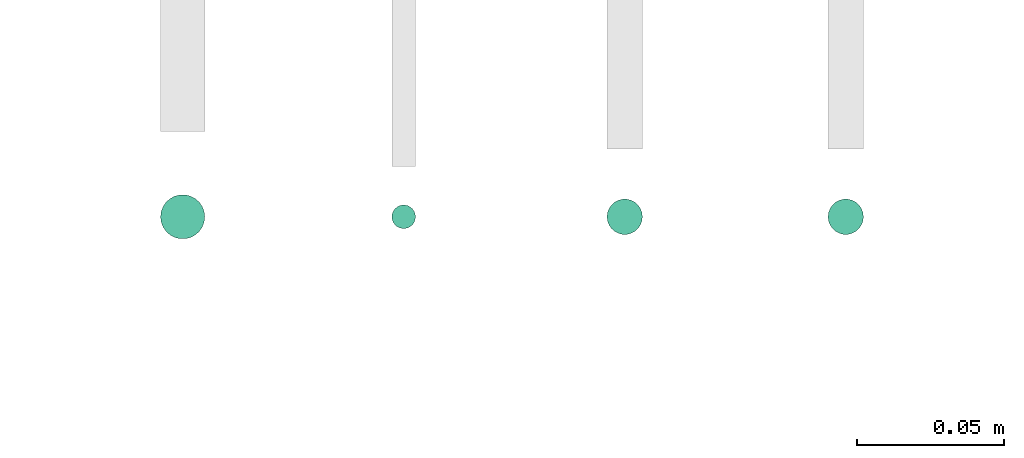
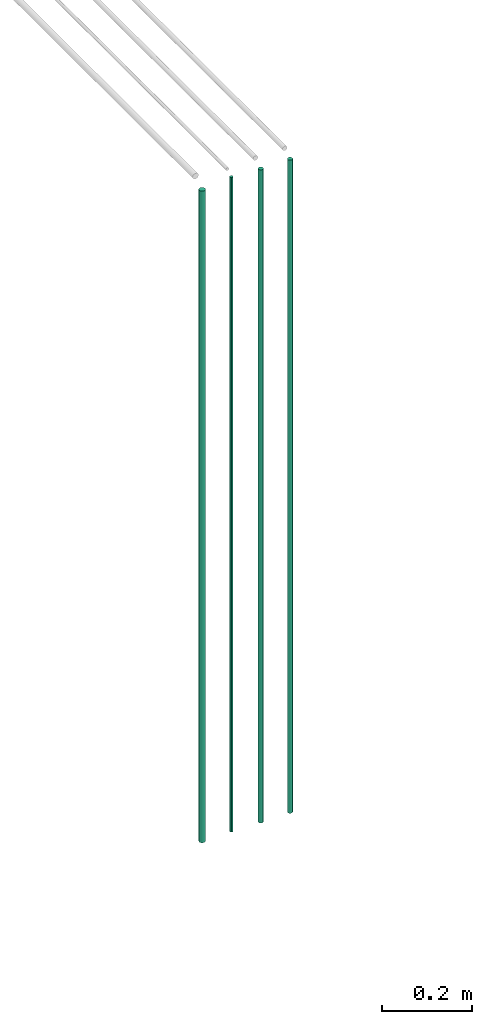
# One storey, part 8 of 65: 4 flow segments.
"""IFC2X3 building model written with IfcOpenShell, lengths in millimetres."""

from ifc_helpers import new_model, entity, si_unit, converted_unit, derived_unit, direction, frame, frame_2d, origin, origin_2d_with_axis, place, context, subcontext, project, spatial, circle, extrude, type_object, element, save


model = new_model("IFC2X3")

# Units and contexts
model_context = context("Model", 3, precision=0.01, world=origin(), true_north=direction((6.12303176911189e-17, 1.0)))
body_context = subcontext(model_context, "Body", "Model", "MODEL_VIEW")
ifc_project = project(units=[si_unit("LENGTHUNIT", "METRE", prefix="MILLI"), si_unit("AREAUNIT", "SQUARE_METRE"), si_unit("VOLUMEUNIT", "CUBIC_METRE"), converted_unit("PLANEANGLEUNIT", "DEGREE", entity("IfcRatioMeasure", 0.0174532925199433), si_unit("PLANEANGLEUNIT", "RADIAN"), dimensions=[0, 0, 0, 0, 0, 0, 0]), si_unit("MASSUNIT", "GRAM", prefix="KILO"), derived_unit("MASSDENSITYUNIT", [(si_unit("MASSUNIT", "GRAM", prefix="KILO"), 1), (si_unit("LENGTHUNIT", "METRE"), -3)]), derived_unit("MOMENTOFINERTIAUNIT", [(si_unit("LENGTHUNIT", "METRE"), 4)]), si_unit("TIMEUNIT", "SECOND"), si_unit("FREQUENCYUNIT", "HERTZ"), si_unit("THERMODYNAMICTEMPERATUREUNIT", "DEGREE_CELSIUS"), derived_unit("THERMALTRANSMITTANCEUNIT", [(si_unit("MASSUNIT", "GRAM", prefix="KILO"), 1), (si_unit("THERMODYNAMICTEMPERATUREUNIT", "KELVIN"), -1), (si_unit("TIMEUNIT", "SECOND"), -3)]), derived_unit("VOLUMETRICFLOWRATEUNIT", [(si_unit("LENGTHUNIT", "METRE"), 3), (si_unit("TIMEUNIT", "SECOND"), -1)]), derived_unit("MASSFLOWRATEUNIT", [(si_unit("MASSUNIT", "GRAM", prefix="KILO"), 1), (si_unit("TIMEUNIT", "SECOND"), -1)]), derived_unit("ROTATIONALFREQUENCYUNIT", [(si_unit("TIMEUNIT", "SECOND"), -1)]), si_unit("ELECTRICCURRENTUNIT", "AMPERE"), si_unit("ELECTRICVOLTAGEUNIT", "VOLT"), si_unit("POWERUNIT", "WATT"), si_unit("FORCEUNIT", "NEWTON", prefix="KILO"), si_unit("ILLUMINANCEUNIT", "LUX"), si_unit("LUMINOUSFLUXUNIT", "LUMEN"), si_unit("LUMINOUSINTENSITYUNIT", "CANDELA"), derived_unit("USERDEFINED", [(si_unit("MASSUNIT", "GRAM", prefix="KILO"), -1), (si_unit("LENGTHUNIT", "METRE"), -2), (si_unit("TIMEUNIT", "SECOND"), 3), (si_unit("LUMINOUSFLUXUNIT", "LUMEN"), 1)]), derived_unit("LINEARVELOCITYUNIT", [(si_unit("LENGTHUNIT", "METRE"), 1), (si_unit("TIMEUNIT", "SECOND"), -1)]), si_unit("PRESSUREUNIT", "PASCAL"), derived_unit("USERDEFINED", [(si_unit("LENGTHUNIT", "METRE"), -2), (si_unit("MASSUNIT", "GRAM", prefix="KILO"), 1), (si_unit("TIMEUNIT", "SECOND"), -2)]), derived_unit("LINEARFORCEUNIT", [(si_unit("MASSUNIT", "GRAM", prefix="KILO"), 1), (si_unit("LENGTHUNIT", "METRE"), 1), (si_unit("TIMEUNIT", "SECOND"), -2), (si_unit("LENGTHUNIT", "METRE"), -1)]), derived_unit("PLANARFORCEUNIT", [(si_unit("MASSUNIT", "GRAM", prefix="KILO"), 1), (si_unit("LENGTHUNIT", "METRE"), 1), (si_unit("TIMEUNIT", "SECOND"), -2), (si_unit("LENGTHUNIT", "METRE"), -2)])], contexts=[model_context])

# Site, building, storey
site_placement = place(None, frame((0.0, -0.00077364408347762, 0.0)))
site = spatial("IfcSite", under=ifc_project, at=site_placement, CompositionType="ELEMENT")
building_placement = place(site_placement, origin())
building = spatial("IfcBuilding", under=site, at=building_placement, CompositionType="ELEMENT")
storey_placement = place(building_placement, frame((0.0, 0.0, 19800.0)))
storey = spatial("IfcBuildingStorey", under=building, at=storey_placement, CompositionType="ELEMENT", Elevation=19800.0)

# Flow segments
pipe_segment_type = type_object("IfcPipeSegmentType", PredefinedType="NOTDEFINED")
flow_segment_1_placement = place(storey_placement, frame((50856.8052438068, 530.904727764077, 1400.0)))
element("IfcFlowSegment", 1, at=flow_segment_1_placement, inside=storey, type_object=pipe_segment_type, context=body_context, shape_type="SweptSolid", body=[
    extrude(circle(Radius=7.5, at=frame_2d((0.0, -6.76791955811495e-14), x_axis=(1.0, 0.0))), frame((9.09527223591419, 9.09527223591589, 0.0), z_axis=(0.0, 0.0, 1.0), x_axis=(-1.0, 0.0, 0.0)), (0.0, 0.0, 1.0), 1761.99999999964),
])
flow_segment_2_placement = place(storey_placement, frame((50935.3052438068, 534.404727764077, 1400.0)))
element("IfcFlowSegment", 2, at=flow_segment_2_placement, inside=storey, type_object=pipe_segment_type, context=body_context, shape_type="SweptSolid", body=[
    extrude(circle(Radius=4.0, at=origin_2d_with_axis()), frame((5.59527223591499, 5.59527223591594, 0.0), z_axis=(0.0, 0.0, 1.0), x_axis=(-1.0, 0.0, 0.0)), (0.0, 0.0, 1.0), 1769.99999999964),
])
for number, where in (
    (3, (51008.3052438068, 532.404727764077, 1400.0)),
    (4, (51083.3052438068, 532.404727764077, 1400.0)),
):
    element("IfcFlowSegment", number, at=place(storey_placement, frame(where)), inside=storey, type_object=pipe_segment_type, context=body_context, shape_type="SweptSolid", body=[
        extrude(circle(Radius=6.0, at=origin_2d_with_axis()), frame((7.59527223591454, 7.59527223591596, 0.0), z_axis=(0.0, 0.0, 1.0), x_axis=(-1.0, 0.0, 0.0)), (0.0, 0.0, 1.0), 1765.99999999964),
    ])

save(model, "model.ifc")
